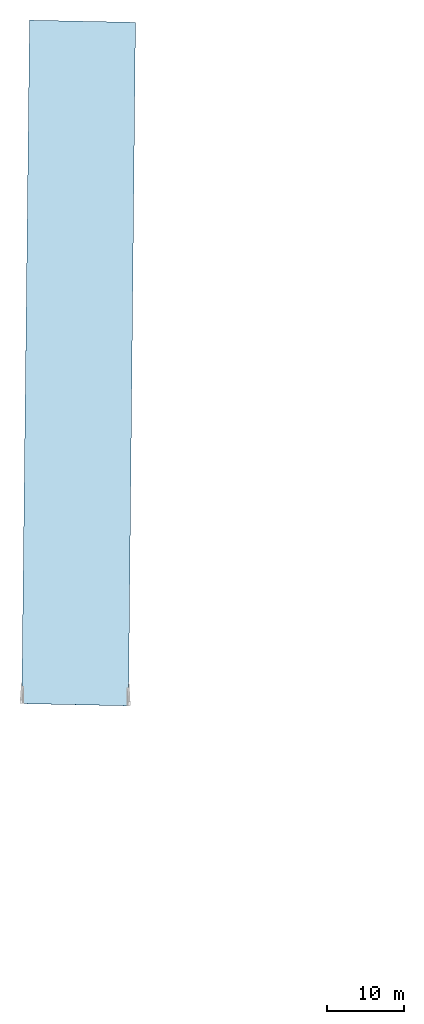
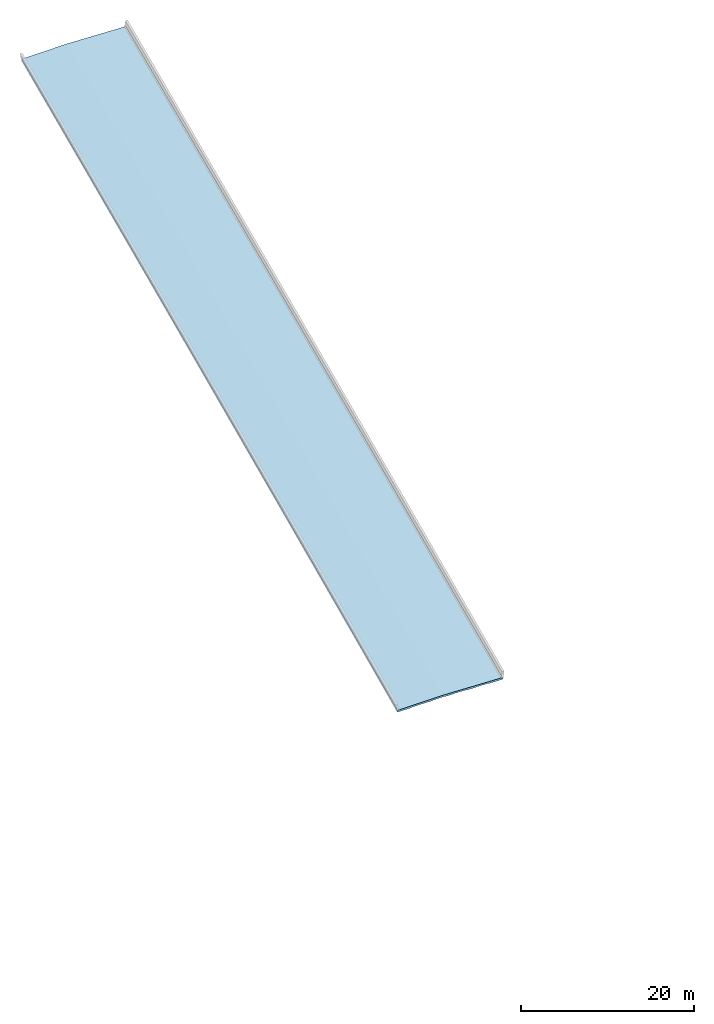
# Not in any storey, part 6 of 7: 1 slab.
"""IFC4X3_ADD2 model written with IfcOpenShell, lengths in metres."""

from ifc_helpers import new_model, entity, si_unit, direction, origin_with_axes, place, context, subcontext, project, spatial, element, save


model = new_model("IFC4X3_ADD2")

# Units and contexts
model_context = context("Model", 3, precision=1e-05, world=origin_with_axes(), true_north=direction((0.0, 1.0)))
body_context = subcontext(model_context, "Body", "Model", "MODEL_VIEW")
ifc_project = project(units=[si_unit("LENGTHUNIT", "METRE"), si_unit("PLANEANGLEUNIT", "RADIAN")], contexts=[model_context])

# Site, bridge, bridge parts
placement = place(None, origin_with_axes())
site = spatial("IfcSite", under=ifc_project, at=placement, CompositionType="ELEMENT")
bridge = spatial("IfcBridge", under=site, CompositionType="COMPLEX", PredefinedType="GIRDER")
bridge_part_1 = spatial("IfcBridgePart", under=bridge, CompositionType="PARTIAL", PredefinedType="SUPERSTRUCTURE", UsageType="LONGITUDINAL")
bridge_part_2 = spatial("IfcBridgePart", under=bridge_part_1, CompositionType="PARTIAL", PredefinedType="DECK", UsageType="LONGITUDINAL")

# Slab
gradient_curve = entity("IfcGradientCurve", [entity("IfcCurveSegment", "CONTSAMEGRADIENT", entity("IfcAxis2Placement2D", entity("IfcCartesianPoint", [0.0, 225.3996]), entity("IfcDirection", [0.999837986875874, 0.018])), entity("IfcLengthMeasure", 0.0), entity("IfcLengthMeasure", 152.4), entity("IfcPolynomialCurve", entity("IfcAxis2Placement2D", entity("IfcCartesianPoint", [0.0, 0.0]), entity("IfcDirection", [1.0, 0.0])), [0.0, 1.0], [225.3996, 0.018, -0.000142388451443569])), entity("IfcCurveSegment", "CONTSAMEGRADIENT", entity("IfcAxis2Placement2D", entity("IfcCartesianPoint", [152.4, 224.83572]), entity("IfcDirection", [0.999677367954282, -0.0253999999999999])), entity("IfcLengthMeasure", 0.0), entity("IfcLengthMeasure", 19.2237360000008), entity("IfcLine", entity("IfcCartesianPoint", [0.0, 0.0]), entity("IfcVector", entity("IfcDirection", [1.0, 0.0]), 1.0))), entity("IfcCurveSegment", "DISCONTINUOUS", entity("IfcAxis2Placement2D", entity("IfcCartesianPoint", [152.4, 224.83572]), entity("IfcDirection", [0.999677367954282, -0.0253999999999999])), entity("IfcLengthMeasure", 0.0), entity("IfcLengthMeasure", 0.0), entity("IfcLine", entity("IfcCartesianPoint", [0.0, 0.0]), entity("IfcVector", entity("IfcDirection", [1.0, 0.0]), 1.0)))], False, entity("IfcCompositeCurve", [entity("IfcCurveSegment", "CONTSAMEGRADIENT", entity("IfcAxis2Placement2D", entity("IfcCartesianPoint", [80.2547679528969, 3851.83601829113]), entity("IfcDirection", [0.0208309370620953, 0.999783012488767])), entity("IfcLengthMeasure", 0.0), entity("IfcLengthMeasure", 171.623736), entity("IfcLine", entity("IfcCartesianPoint", [0.0, 0.0]), entity("IfcVector", entity("IfcDirection", [1.0, 0.0]), 1.0))), entity("IfcCurveSegment", "DISCONTINUOUS", entity("IfcAxis2Placement2D", entity("IfcCartesianPoint", [83.8298511958746, 4023.42251408378]), entity("IfcDirection", [0.0208309370620953, 0.999783012488767])), entity("IfcLengthMeasure", 0.0), entity("IfcLengthMeasure", 0.0), entity("IfcLine", entity("IfcCartesianPoint", [0.0, 0.0]), entity("IfcVector", entity("IfcDirection", [1.0, 0.0]), 1.0)))], False))
cartesian_point_1 = entity("IfcCartesianPoint", [-7.8422500001016, -0.385445000002051])
cartesian_point_2 = entity("IfcCartesianPoint", [-7.83526500009144, -0.385305300001846])
cartesian_point_3 = entity("IfcCartesianPoint", [-7.82828000008128, -0.385165600001642])
cartesian_point_4 = entity("IfcCartesianPoint", [-7.82129500007112, -0.385025900001438])
cartesian_point_5 = entity("IfcCartesianPoint", [-7.81431000006096, -0.384886200001233])
cartesian_point_6 = entity("IfcCartesianPoint", [-7.80732500005081, -0.384746500001029])
cartesian_point_7 = entity("IfcCartesianPoint", [-7.80034000004064, -0.384606800000824])
cartesian_point_8 = entity("IfcCartesianPoint", [-7.79335500003049, -0.38446710000062])
cartesian_point_9 = entity("IfcCartesianPoint", [-7.78637000002032, -0.384327400000416])
cartesian_point_10 = entity("IfcCartesianPoint", [-7.77938500001017, -0.384187700000183])
cartesian_point_11 = entity("IfcCartesianPoint", [-7.77240000000001, -0.384048000000007])
element("IfcSlab", 1, at=placement, inside=bridge_part_2, Name="Deck Slab", PredefinedType="FLOOR", context=body_context, shape_type="AdvancedSweptSolid", body=[
    entity("IfcSectionedSolidHorizontal", gradient_curve, [entity("IfcArbitraryClosedProfileDef", "AREA", None, entity("IfcPolyline", [cartesian_point_1, entity("IfcCartesianPoint", [-7.8422500001016, -0.15684500000205]), entity("IfcCartesianPoint", [0.0, 0.0]), entity("IfcCartesianPoint", [6.021705, -0.120434099999983]), entity("IfcCartesianPoint", [6.021705, -0.349034099999983]), entity("IfcCartesianPoint", [5.52439840000044, -0.364741967999976]), entity("IfcCartesianPoint", [4.27979840000044, -0.364741967999976]), entity("IfcCartesianPoint", [4.27979840000044, -0.333245968]), entity("IfcCartesianPoint", [4.26074840000044, -0.314195968000007]), entity("IfcCartesianPoint", [2.64784840000042, -0.281175968000014]), entity("IfcCartesianPoint", [2.62879840000042, -0.300225968000007]), entity("IfcCartesianPoint", [2.62879840000042, -0.306829967999988]), entity("IfcCartesianPoint", [1.38419840000042, -0.306829967999988]), entity("IfcCartesianPoint", [1.38419840000042, -0.275333968000012]), entity("IfcCartesianPoint", [1.36514840000042, -0.25628396800002]), entity("IfcCartesianPoint", [-0.247751599999577, -0.233936032000003]), entity("IfcCartesianPoint", [-0.266801599999577, -0.252986031999995]), entity("IfcCartesianPoint", [-0.266801599999577, -0.284482032]), entity("IfcCartesianPoint", [-1.51140159999958, -0.284482032]), entity("IfcCartesianPoint", [-1.51140159999958, -0.27787803199999]), entity("IfcCartesianPoint", [-1.53045159999958, -0.258828031999997]), entity("IfcCartesianPoint", [-3.14335159999956, -0.29184803199999]), entity("IfcCartesianPoint", [-3.16240159999956, -0.310898031999983]), entity("IfcCartesianPoint", [-3.16240159999956, -0.342394031999987]), entity("IfcCartesianPoint", [-4.40700159999956, -0.342394031999987]), entity("IfcCartesianPoint", [-4.40700159999956, -0.335790031999977]), entity("IfcCartesianPoint", [-4.42605159999956, -0.316740031999984]), entity("IfcCartesianPoint", [-6.03895159999957, -0.349760031999978]), entity("IfcCartesianPoint", [-6.05800159999957, -0.368810031999971]), entity("IfcCartesianPoint", [-6.05800159999957, -0.400306031999975]), entity("IfcCartesianPoint", [-7.30260159999957, -0.400306031999975]), cartesian_point_1])), entity("IfcArbitraryClosedProfileDef", "AREA", None, entity("IfcPolyline", [cartesian_point_2, entity("IfcCartesianPoint", [-7.83526500009144, -0.156705300001846]), entity("IfcCartesianPoint", [0.0, 0.0]), entity("IfcCartesianPoint", [6.018657, -0.120373139999998]), entity("IfcCartesianPoint", [6.018657, -0.348973139999998]), entity("IfcCartesianPoint", [5.52439840000045, -0.357883967999982]), entity("IfcCartesianPoint", [4.27979840000045, -0.357883967999982]), entity("IfcCartesianPoint", [4.27979840000045, -0.333245968]), entity("IfcCartesianPoint", [4.26074840000045, -0.314195968000007]), entity("IfcCartesianPoint", [2.64784840000043, -0.281175968000014]), entity("IfcCartesianPoint", [2.62879840000043, -0.300225968000007]), entity("IfcCartesianPoint", [2.62879840000043, -0.299971967999994]), entity("IfcCartesianPoint", [1.38419840000043, -0.299971967999994]), entity("IfcCartesianPoint", [1.38419840000043, -0.275333968000012]), entity("IfcCartesianPoint", [1.36514840000043, -0.25628396800002]), entity("IfcCartesianPoint", [-0.247751599999572, -0.233936032000003]), entity("IfcCartesianPoint", [-0.266801599999572, -0.252986031999995]), entity("IfcCartesianPoint", [-0.266801599999572, -0.277624032000006]), entity("IfcCartesianPoint", [-1.51140159999957, -0.277624032000006]), entity("IfcCartesianPoint", [-1.51140159999957, -0.27787803199999]), entity("IfcCartesianPoint", [-1.53045159999957, -0.258828031999997]), entity("IfcCartesianPoint", [-3.14335159999956, -0.29184803199999]), entity("IfcCartesianPoint", [-3.16240159999956, -0.310898031999983]), entity("IfcCartesianPoint", [-3.16240159999956, -0.335536031999993]), entity("IfcCartesianPoint", [-4.40700159999956, -0.335536031999993]), entity("IfcCartesianPoint", [-4.40700159999956, -0.335790031999977]), entity("IfcCartesianPoint", [-4.42605159999956, -0.316740031999984]), entity("IfcCartesianPoint", [-6.03895159999956, -0.349760031999978]), entity("IfcCartesianPoint", [-6.05800159999956, -0.368810031999971]), entity("IfcCartesianPoint", [-6.05800159999956, -0.393448031999981]), entity("IfcCartesianPoint", [-7.30260159999956, -0.393448031999981]), cartesian_point_2])), entity("IfcArbitraryClosedProfileDef", "AREA", None, entity("IfcPolyline", [cartesian_point_3, entity("IfcCartesianPoint", [-7.82828000008128, -0.156565600001642]), entity("IfcCartesianPoint", [0.0, 0.0]), entity("IfcCartesianPoint", [6.015609, -0.120312179999985]), entity("IfcCartesianPoint", [6.015609, -0.348912179999985]), entity("IfcCartesianPoint", [5.52439840000044, -0.352549967999977]), entity("IfcCartesianPoint", [4.27979840000044, -0.352549967999977]), entity("IfcCartesianPoint", [4.27979840000044, -0.333245968]), entity("IfcCartesianPoint", [4.26074840000044, -0.314195968000007]), entity("IfcCartesianPoint", [2.64784840000042, -0.281175968000014]), entity("IfcCartesianPoint", [2.62879840000042, -0.300225968000007]), entity("IfcCartesianPoint", [2.62879840000042, -0.294637967999989]), entity("IfcCartesianPoint", [1.38419840000042, -0.294637967999989]), entity("IfcCartesianPoint", [1.38419840000042, -0.275333968000012]), entity("IfcCartesianPoint", [1.36514840000042, -0.25628396800002]), entity("IfcCartesianPoint", [-0.247751599999577, -0.233936032000003]), entity("IfcCartesianPoint", [-0.266801599999577, -0.252986031999995]), entity("IfcCartesianPoint", [-0.266801599999577, -0.272290032000001]), entity("IfcCartesianPoint", [-1.51140159999958, -0.272290032000001]), entity("IfcCartesianPoint", [-1.51140159999958, -0.27787803199999]), entity("IfcCartesianPoint", [-1.53045159999958, -0.258828031999997]), entity("IfcCartesianPoint", [-3.14335159999956, -0.29184803199999]), entity("IfcCartesianPoint", [-3.16240159999956, -0.310898031999983]), entity("IfcCartesianPoint", [-3.16240159999956, -0.330202031999988]), entity("IfcCartesianPoint", [-4.40700159999956, -0.330202031999988]), entity("IfcCartesianPoint", [-4.40700159999956, -0.335790031999977]), entity("IfcCartesianPoint", [-4.42605159999956, -0.316740031999984]), entity("IfcCartesianPoint", [-6.03895159999957, -0.349760031999978]), entity("IfcCartesianPoint", [-6.05800159999957, -0.368810031999971]), entity("IfcCartesianPoint", [-6.05800159999957, -0.388114031999976]), entity("IfcCartesianPoint", [-7.30260159999957, -0.388114031999976]), cartesian_point_3])), entity("IfcArbitraryClosedProfileDef", "AREA", None, entity("IfcPolyline", [cartesian_point_4, entity("IfcCartesianPoint", [-7.82129500007112, -0.156425900001437]), entity("IfcCartesianPoint", [0.0, 0.0]), entity("IfcCartesianPoint", [6.012561, -0.12025122]), entity("IfcCartesianPoint", [6.012561, -0.34885122]), entity("IfcCartesianPoint", [5.52439840000045, -0.34873996799999]), entity("IfcCartesianPoint", [4.27979840000045, -0.34873996799999]), entity("IfcCartesianPoint", [4.27979840000045, -0.333245968]), entity("IfcCartesianPoint", [4.26074840000045, -0.314195968000007]), entity("IfcCartesianPoint", [2.64784840000043, -0.281175968000014]), entity("IfcCartesianPoint", [2.62879840000043, -0.300225968000007]), entity("IfcCartesianPoint", [2.62879840000043, -0.290827968000002]), entity("IfcCartesianPoint", [1.38419840000043, -0.290827968000002]), entity("IfcCartesianPoint", [1.38419840000043, -0.275333968000012]), entity("IfcCartesianPoint", [1.36514840000043, -0.25628396800002]), entity("IfcCartesianPoint", [-0.247751599999572, -0.233936032000003]), entity("IfcCartesianPoint", [-0.266801599999572, -0.252986031999995]), entity("IfcCartesianPoint", [-0.266801599999572, -0.268480032000014]), entity("IfcCartesianPoint", [-1.51140159999957, -0.268480032000014]), entity("IfcCartesianPoint", [-1.51140159999957, -0.27787803199999]), entity("IfcCartesianPoint", [-1.53045159999957, -0.258828031999997]), entity("IfcCartesianPoint", [-3.14335159999956, -0.29184803199999]), entity("IfcCartesianPoint", [-3.16240159999956, -0.310898031999983]), entity("IfcCartesianPoint", [-3.16240159999956, -0.326392032000001]), entity("IfcCartesianPoint", [-4.40700159999956, -0.326392032000001]), entity("IfcCartesianPoint", [-4.40700159999956, -0.335790031999977]), entity("IfcCartesianPoint", [-4.42605159999956, -0.316740031999984]), entity("IfcCartesianPoint", [-6.03895159999956, -0.349760031999978]), entity("IfcCartesianPoint", [-6.05800159999956, -0.368810031999971]), entity("IfcCartesianPoint", [-6.05800159999956, -0.384304031999989]), entity("IfcCartesianPoint", [-7.30260159999956, -0.384304031999989]), cartesian_point_4])), entity("IfcArbitraryClosedProfileDef", "AREA", None, entity("IfcPolyline", [cartesian_point_5, entity("IfcCartesianPoint", [-7.81431000006096, -0.156286200001233]), entity("IfcCartesianPoint", [0.0, 0.0]), entity("IfcCartesianPoint", [6.009513, -0.120190259999987]), entity("IfcCartesianPoint", [6.009513, -0.348790259999987]), entity("IfcCartesianPoint", [5.52439840000045, -0.346453967999992]), entity("IfcCartesianPoint", [4.27979840000045, -0.346453967999992]), entity("IfcCartesianPoint", [4.27979840000045, -0.333245968]), entity("IfcCartesianPoint", [4.26074840000045, -0.314195968000007]), entity("IfcCartesianPoint", [2.64784840000043, -0.281175968000014]), entity("IfcCartesianPoint", [2.62879840000043, -0.300225968000007]), entity("IfcCartesianPoint", [2.62879840000043, -0.288541968000004]), entity("IfcCartesianPoint", [1.38419840000043, -0.288541968000004]), entity("IfcCartesianPoint", [1.38419840000043, -0.275333968000012]), entity("IfcCartesianPoint", [1.36514840000043, -0.25628396800002]), entity("IfcCartesianPoint", [-0.247751599999567, -0.233936032000003]), entity("IfcCartesianPoint", [-0.266801599999567, -0.252986031999995]), entity("IfcCartesianPoint", [-0.266801599999567, -0.266194032000016]), entity("IfcCartesianPoint", [-1.51140159999957, -0.266194032000016]), entity("IfcCartesianPoint", [-1.51140159999957, -0.27787803199999]), entity("IfcCartesianPoint", [-1.53045159999957, -0.258828031999997]), entity("IfcCartesianPoint", [-3.14335159999955, -0.29184803199999]), entity("IfcCartesianPoint", [-3.16240159999955, -0.310898031999983]), entity("IfcCartesianPoint", [-3.16240159999955, -0.324106032000003]), entity("IfcCartesianPoint", [-4.40700159999955, -0.324106032000003]), entity("IfcCartesianPoint", [-4.40700159999955, -0.335790031999977]), entity("IfcCartesianPoint", [-4.42605159999955, -0.316740031999984]), entity("IfcCartesianPoint", [-6.03895159999956, -0.349760031999978]), entity("IfcCartesianPoint", [-6.05800159999956, -0.368810031999971]), entity("IfcCartesianPoint", [-6.05800159999956, -0.382018031999991]), entity("IfcCartesianPoint", [-7.30260159999956, -0.382018031999991]), cartesian_point_5])), entity("IfcArbitraryClosedProfileDef", "AREA", None, entity("IfcPolyline", [cartesian_point_6, entity("IfcCartesianPoint", [-7.80732500005081, -0.156146500001029]), entity("IfcCartesianPoint", [0.0, 0.0]), entity("IfcCartesianPoint", [6.006465, -0.120129300000002]), entity("IfcCartesianPoint", [6.006465, -0.348729300000002]), entity("IfcCartesianPoint", [5.52439840000045, -0.345691967999983]), entity("IfcCartesianPoint", [4.27979840000045, -0.345691967999983]), entity("IfcCartesianPoint", [4.27979840000045, -0.333245968]), entity("IfcCartesianPoint", [4.26074840000045, -0.314195968000007]), entity("IfcCartesianPoint", [2.64784840000043, -0.281175968000014]), entity("IfcCartesianPoint", [2.62879840000043, -0.300225968000007]), entity("IfcCartesianPoint", [2.62879840000043, -0.287779967999995]), entity("IfcCartesianPoint", [1.38419840000043, -0.287779967999995]), entity("IfcCartesianPoint", [1.38419840000043, -0.275333968000012]), entity("IfcCartesianPoint", [1.36514840000043, -0.25628396800002]), entity("IfcCartesianPoint", [-0.247751599999571, -0.233936032000003]), entity("IfcCartesianPoint", [-0.266801599999571, -0.252986031999995]), entity("IfcCartesianPoint", [-0.266801599999571, -0.265432032000007]), entity("IfcCartesianPoint", [-1.51140159999957, -0.265432032000007]), entity("IfcCartesianPoint", [-1.51140159999957, -0.27787803199999]), entity("IfcCartesianPoint", [-1.53045159999957, -0.258828031999997]), entity("IfcCartesianPoint", [-3.14335159999956, -0.29184803199999]), entity("IfcCartesianPoint", [-3.16240159999956, -0.310898031999983]), entity("IfcCartesianPoint", [-3.16240159999956, -0.323344031999994]), entity("IfcCartesianPoint", [-4.40700159999956, -0.323344031999994]), entity("IfcCartesianPoint", [-4.40700159999956, -0.335790031999977]), entity("IfcCartesianPoint", [-4.42605159999956, -0.316740031999984]), entity("IfcCartesianPoint", [-6.03895159999956, -0.349760031999978]), entity("IfcCartesianPoint", [-6.05800159999956, -0.368810031999971]), entity("IfcCartesianPoint", [-6.05800159999956, -0.381256031999982]), entity("IfcCartesianPoint", [-7.30260159999956, -0.381256031999982]), cartesian_point_6])), entity("IfcArbitraryClosedProfileDef", "AREA", None, entity("IfcPolyline", [cartesian_point_7, entity("IfcCartesianPoint", [-7.80034000004064, -0.156006800000824]), entity("IfcCartesianPoint", [0.0, 0.0]), entity("IfcCartesianPoint", [6.003417, -0.120068339999989]), entity("IfcCartesianPoint", [6.003417, -0.348668339999989]), entity("IfcCartesianPoint", [5.52439840000045, -0.346453967999992]), entity("IfcCartesianPoint", [4.27979840000045, -0.346453967999992]), entity("IfcCartesianPoint", [4.27979840000045, -0.333245968]), entity("IfcCartesianPoint", [4.26074840000045, -0.314195968000007]), entity("IfcCartesianPoint", [2.64784840000044, -0.281175968000014]), entity("IfcCartesianPoint", [2.62879840000044, -0.300225968000007]), entity("IfcCartesianPoint", [2.62879840000044, -0.288541968000004]), entity("IfcCartesianPoint", [1.38419840000044, -0.288541968000004]), entity("IfcCartesianPoint", [1.38419840000044, -0.275333968000012]), entity("IfcCartesianPoint", [1.36514840000044, -0.25628396800002]), entity("IfcCartesianPoint", [-0.247751599999566, -0.233936032000003]), entity("IfcCartesianPoint", [-0.266801599999566, -0.252986031999995]), entity("IfcCartesianPoint", [-0.266801599999566, -0.266194032000016]), entity("IfcCartesianPoint", [-1.51140159999957, -0.266194032000016]), entity("IfcCartesianPoint", [-1.51140159999957, -0.27787803199999]), entity("IfcCartesianPoint", [-1.53045159999957, -0.258828031999997]), entity("IfcCartesianPoint", [-3.14335159999955, -0.29184803199999]), entity("IfcCartesianPoint", [-3.16240159999955, -0.310898031999983]), entity("IfcCartesianPoint", [-3.16240159999955, -0.324106032000003]), entity("IfcCartesianPoint", [-4.40700159999955, -0.324106032000003]), entity("IfcCartesianPoint", [-4.40700159999955, -0.335790031999977]), entity("IfcCartesianPoint", [-4.42605159999955, -0.316740031999984]), entity("IfcCartesianPoint", [-6.03895159999956, -0.349760031999978]), entity("IfcCartesianPoint", [-6.05800159999956, -0.368810031999971]), entity("IfcCartesianPoint", [-6.05800159999956, -0.382018031999991]), entity("IfcCartesianPoint", [-7.30260159999956, -0.382018031999991]), cartesian_point_7])), entity("IfcArbitraryClosedProfileDef", "AREA", None, entity("IfcPolyline", [cartesian_point_8, entity("IfcCartesianPoint", [-7.79335500003049, -0.15586710000062]), entity("IfcCartesianPoint", [0.0, 0.0]), entity("IfcCartesianPoint", [6.00036899999999, -0.120007380000004]), entity("IfcCartesianPoint", [6.00036899999999, -0.348607380000004]), entity("IfcCartesianPoint", [5.52439840000044, -0.34873996799999]), entity("IfcCartesianPoint", [4.27979840000044, -0.34873996799999]), entity("IfcCartesianPoint", [4.27979840000044, -0.333245968]), entity("IfcCartesianPoint", [4.26074840000044, -0.314195968000007]), entity("IfcCartesianPoint", [2.64784840000043, -0.281175968000014]), entity("IfcCartesianPoint", [2.62879840000043, -0.300225968000007]), entity("IfcCartesianPoint", [2.62879840000043, -0.290827968000002]), entity("IfcCartesianPoint", [1.38419840000043, -0.290827968000002]), entity("IfcCartesianPoint", [1.38419840000043, -0.275333968000012]), entity("IfcCartesianPoint", [1.36514840000043, -0.25628396800002]), entity("IfcCartesianPoint", [-0.247751599999576, -0.233936032000003]), entity("IfcCartesianPoint", [-0.266801599999576, -0.252986031999995]), entity("IfcCartesianPoint", [-0.266801599999576, -0.268480032000014]), entity("IfcCartesianPoint", [-1.51140159999958, -0.268480032000014]), entity("IfcCartesianPoint", [-1.51140159999958, -0.27787803199999]), entity("IfcCartesianPoint", [-1.53045159999958, -0.258828031999997]), entity("IfcCartesianPoint", [-3.14335159999956, -0.29184803199999]), entity("IfcCartesianPoint", [-3.16240159999956, -0.310898031999983]), entity("IfcCartesianPoint", [-3.16240159999956, -0.326392032000001]), entity("IfcCartesianPoint", [-4.40700159999956, -0.326392032000001]), entity("IfcCartesianPoint", [-4.40700159999956, -0.335790031999977]), entity("IfcCartesianPoint", [-4.42605159999956, -0.316740031999984]), entity("IfcCartesianPoint", [-6.03895159999957, -0.349760031999978]), entity("IfcCartesianPoint", [-6.05800159999957, -0.368810031999971]), entity("IfcCartesianPoint", [-6.05800159999957, -0.384304031999989]), entity("IfcCartesianPoint", [-7.30260159999957, -0.384304031999989]), cartesian_point_8])), entity("IfcArbitraryClosedProfileDef", "AREA", None, entity("IfcPolyline", [cartesian_point_9, entity("IfcCartesianPoint", [-7.78637000002032, -0.155727400000416]), entity("IfcCartesianPoint", [0.0, 0.0]), entity("IfcCartesianPoint", [5.997321, -0.119946419999991]), entity("IfcCartesianPoint", [5.997321, -0.348546419999991]), entity("IfcCartesianPoint", [5.52439840000046, -0.352549967999977]), entity("IfcCartesianPoint", [4.27979840000046, -0.352549967999977]), entity("IfcCartesianPoint", [4.27979840000046, -0.333245968]), entity("IfcCartesianPoint", [4.26074840000046, -0.314195968000007]), entity("IfcCartesianPoint", [2.64784840000044, -0.281175968000014]), entity("IfcCartesianPoint", [2.62879840000044, -0.300225968000007]), entity("IfcCartesianPoint", [2.62879840000044, -0.294637967999989]), entity("IfcCartesianPoint", [1.38419840000044, -0.294637967999989]), entity("IfcCartesianPoint", [1.38419840000044, -0.275333968000012]), entity("IfcCartesianPoint", [1.36514840000044, -0.25628396800002]), entity("IfcCartesianPoint", [-0.247751599999561, -0.233936032000003]), entity("IfcCartesianPoint", [-0.266801599999561, -0.252986031999995]), entity("IfcCartesianPoint", [-0.266801599999561, -0.272290032000001]), entity("IfcCartesianPoint", [-1.51140159999956, -0.272290032000001]), entity("IfcCartesianPoint", [-1.51140159999956, -0.27787803199999]), entity("IfcCartesianPoint", [-1.53045159999956, -0.258828031999997]), entity("IfcCartesianPoint", [-3.14335159999955, -0.29184803199999]), entity("IfcCartesianPoint", [-3.16240159999955, -0.310898031999983]), entity("IfcCartesianPoint", [-3.16240159999955, -0.330202031999988]), entity("IfcCartesianPoint", [-4.40700159999955, -0.330202031999988]), entity("IfcCartesianPoint", [-4.40700159999955, -0.335790031999977]), entity("IfcCartesianPoint", [-4.42605159999955, -0.316740031999984]), entity("IfcCartesianPoint", [-6.03895159999955, -0.349760031999978]), entity("IfcCartesianPoint", [-6.05800159999955, -0.368810031999971]), entity("IfcCartesianPoint", [-6.05800159999955, -0.388114031999976]), entity("IfcCartesianPoint", [-7.30260159999955, -0.388114031999976]), cartesian_point_9])), entity("IfcArbitraryClosedProfileDef", "AREA", None, entity("IfcPolyline", [cartesian_point_10, entity("IfcCartesianPoint", [-7.77938500001017, -0.155587700000183]), entity("IfcCartesianPoint", [0.0, 0.0]), entity("IfcCartesianPoint", [5.99427299999999, -0.119885459999949]), entity("IfcCartesianPoint", [5.99427299999999, -0.348485459999949]), entity("IfcCartesianPoint", [5.52439840000045, -0.357883967999953]), entity("IfcCartesianPoint", [4.27979840000045, -0.357883967999953]), entity("IfcCartesianPoint", [4.27979840000045, -0.333245967999972]), entity("IfcCartesianPoint", [4.26074840000045, -0.314195967999979]), entity("IfcCartesianPoint", [2.64784840000044, -0.281175967999985]), entity("IfcCartesianPoint", [2.62879840000044, -0.300225967999978]), entity("IfcCartesianPoint", [2.62879840000044, -0.299971967999966]), entity("IfcCartesianPoint", [1.38419840000044, -0.299971967999966]), entity("IfcCartesianPoint", [1.38419840000044, -0.275333967999984]), entity("IfcCartesianPoint", [1.36514840000044, -0.256283967999991]), entity("IfcCartesianPoint", [-0.247751599999566, -0.233936031999974]), entity("IfcCartesianPoint", [-0.266801599999566, -0.252986031999967]), entity("IfcCartesianPoint", [-0.266801599999566, -0.277624031999977]), entity("IfcCartesianPoint", [-1.51140159999957, -0.277624031999977]), entity("IfcCartesianPoint", [-1.51140159999957, -0.277878031999961]), entity("IfcCartesianPoint", [-1.53045159999957, -0.258828031999968]), entity("IfcCartesianPoint", [-3.14335159999955, -0.291848031999962]), entity("IfcCartesianPoint", [-3.16240159999955, -0.310898031999955]), entity("IfcCartesianPoint", [-3.16240159999955, -0.335536031999965]), entity("IfcCartesianPoint", [-4.40700159999955, -0.335536031999965]), entity("IfcCartesianPoint", [-4.40700159999955, -0.335790031999949]), entity("IfcCartesianPoint", [-4.42605159999955, -0.316740031999956]), entity("IfcCartesianPoint", [-6.03895159999955, -0.349760031999949]), entity("IfcCartesianPoint", [-6.05800159999955, -0.368810031999942]), entity("IfcCartesianPoint", [-6.05800159999955, -0.393448031999952]), entity("IfcCartesianPoint", [-7.30260159999956, -0.393448031999952]), cartesian_point_10])), entity("IfcArbitraryClosedProfileDef", "AREA", None, entity("IfcPolyline", [cartesian_point_11, entity("IfcCartesianPoint", [-7.77240000000001, -0.155448000000007]), entity("IfcCartesianPoint", [0.0, 0.0]), entity("IfcCartesianPoint", [5.991225, -0.119824499999993]), entity("IfcCartesianPoint", [5.991225, -0.348424499999993]), entity("IfcCartesianPoint", [5.52439840000046, -0.364741967999976]), entity("IfcCartesianPoint", [4.27979840000046, -0.364741967999976]), entity("IfcCartesianPoint", [4.27979840000046, -0.333245968]), entity("IfcCartesianPoint", [4.26074840000046, -0.314195968000007]), entity("IfcCartesianPoint", [2.64784840000044, -0.281175968000014]), entity("IfcCartesianPoint", [2.62879840000044, -0.300225968000007]), entity("IfcCartesianPoint", [2.62879840000044, -0.306829967999988]), entity("IfcCartesianPoint", [1.38419840000044, -0.306829967999988]), entity("IfcCartesianPoint", [1.38419840000044, -0.275333968000012]), entity("IfcCartesianPoint", [1.36514840000044, -0.25628396800002]), entity("IfcCartesianPoint", [-0.247751599999561, -0.233936032000003]), entity("IfcCartesianPoint", [-0.266801599999561, -0.252986031999995]), entity("IfcCartesianPoint", [-0.266801599999561, -0.284482032]), entity("IfcCartesianPoint", [-1.51140159999956, -0.284482032]), entity("IfcCartesianPoint", [-1.51140159999956, -0.27787803199999]), entity("IfcCartesianPoint", [-1.53045159999956, -0.258828031999997]), entity("IfcCartesianPoint", [-3.14335159999955, -0.29184803199999]), entity("IfcCartesianPoint", [-3.16240159999955, -0.310898031999983]), entity("IfcCartesianPoint", [-3.16240159999955, -0.342394031999987]), entity("IfcCartesianPoint", [-4.40700159999955, -0.342394031999987]), entity("IfcCartesianPoint", [-4.40700159999955, -0.335790031999977]), entity("IfcCartesianPoint", [-4.42605159999955, -0.316740031999984]), entity("IfcCartesianPoint", [-6.03895159999955, -0.349760031999978]), entity("IfcCartesianPoint", [-6.05800159999955, -0.368810031999971]), entity("IfcCartesianPoint", [-6.05800159999955, -0.400306031999975]), entity("IfcCartesianPoint", [-7.30260159999955, -0.400306031999975]), cartesian_point_11]))], [entity("IfcAxis2PlacementLinear", entity("IfcPointByDistanceExpression", entity("IfcLengthMeasure", 88.1816879999997), None, None, None, gradient_curve)), entity("IfcAxis2PlacementLinear", entity("IfcPointByDistanceExpression", entity("IfcLengthMeasure", 92.3537903999995), None, None, None, gradient_curve)), entity("IfcAxis2PlacementLinear", entity("IfcPointByDistanceExpression", entity("IfcLengthMeasure", 96.5258927999998), None, None, None, gradient_curve)), entity("IfcAxis2PlacementLinear", entity("IfcPointByDistanceExpression", entity("IfcLengthMeasure", 100.6979952), None, None, None, gradient_curve)), entity("IfcAxis2PlacementLinear", entity("IfcPointByDistanceExpression", entity("IfcLengthMeasure", 104.8700976), None, None, None, gradient_curve)), entity("IfcAxis2PlacementLinear", entity("IfcPointByDistanceExpression", entity("IfcLengthMeasure", 109.0422), None, None, None, gradient_curve)), entity("IfcAxis2PlacementLinear", entity("IfcPointByDistanceExpression", entity("IfcLengthMeasure", 113.2143024), None, None, None, gradient_curve)), entity("IfcAxis2PlacementLinear", entity("IfcPointByDistanceExpression", entity("IfcLengthMeasure", 117.3864048), None, None, None, gradient_curve)), entity("IfcAxis2PlacementLinear", entity("IfcPointByDistanceExpression", entity("IfcLengthMeasure", 121.558507199999), None, None, None, gradient_curve)), entity("IfcAxis2PlacementLinear", entity("IfcPointByDistanceExpression", entity("IfcLengthMeasure", 125.7306096), None, None, None, gradient_curve)), entity("IfcAxis2PlacementLinear", entity("IfcPointByDistanceExpression", entity("IfcLengthMeasure", 129.902712), None, None, None, gradient_curve))]),
])

save(model, "model.ifc")
